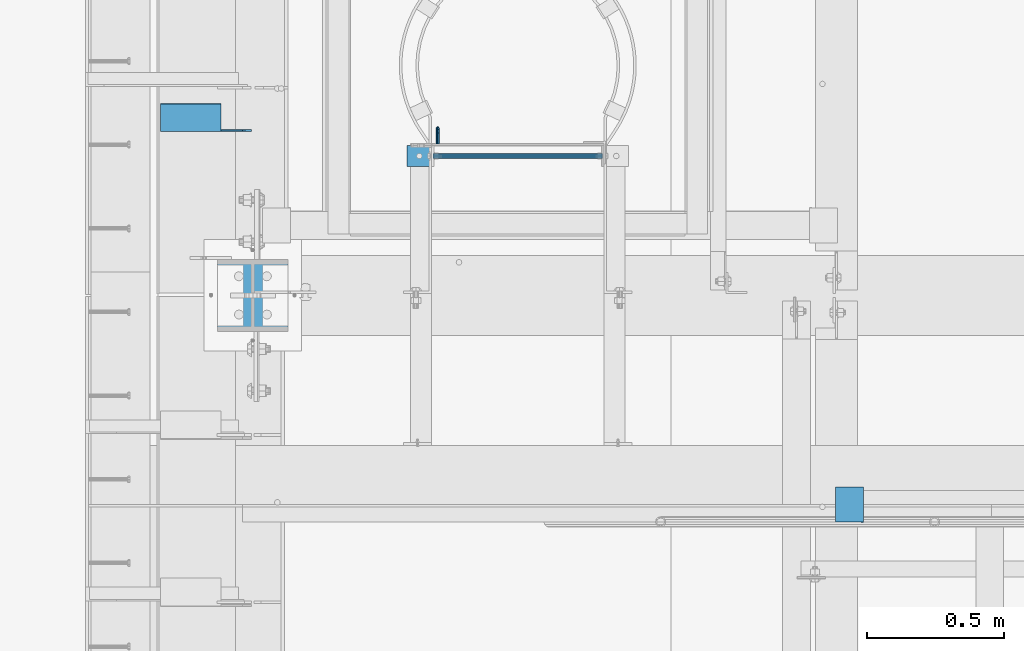
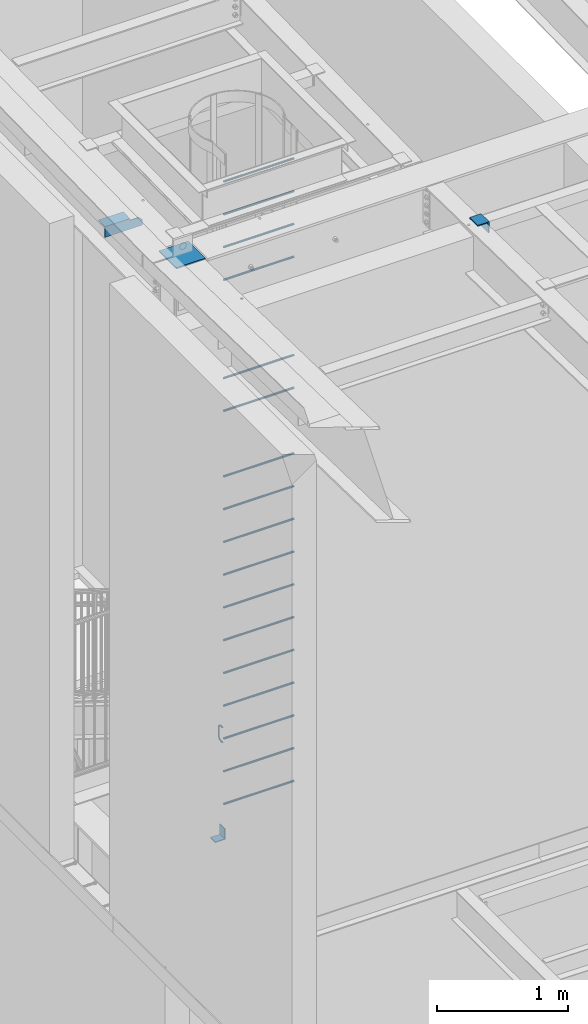
# One storey, part 1255 of 1763: 22 beams, 4 elements without a shape of their own.
"""IFC2X3 building model written with IfcOpenShell, lengths in millimetres."""

from ifc_helpers import new_model, si_unit, frame, origin_with_axes, place, context, subcontext, project, spatial, faceted_brep, material, type_object, element, aggregate, save


model = new_model("IFC2X3")

# Units and contexts
model_context = context("Model", 3, precision=1e-05, world=origin_with_axes())
body_context = subcontext(model_context, "Body", "Model", "MODEL_VIEW")
ifc_project = project(units=[si_unit("LENGTHUNIT", "METRE", prefix="MILLI"), si_unit("AREAUNIT", "SQUARE_METRE"), si_unit("VOLUMEUNIT", "CUBIC_METRE"), si_unit("MASSUNIT", "GRAM", prefix="KILO"), si_unit("TIMEUNIT", "SECOND"), si_unit("PLANEANGLEUNIT", "RADIAN"), si_unit("SOLIDANGLEUNIT", "STERADIAN"), si_unit("THERMODYNAMICTEMPERATUREUNIT", "DEGREE_CELSIUS"), si_unit("LUMINOUSINTENSITYUNIT", "LUMEN")], contexts=[model_context])

# Site, building, storey
site_placement = place(None, origin_with_axes())
site = spatial("IfcSite", under=ifc_project, at=site_placement, CompositionType="ELEMENT")
building_placement = place(site_placement, origin_with_axes())
building = spatial("IfcBuilding", under=site, at=building_placement, Name="Undefined", CompositionType="ELEMENT")
storey_placement = place(building_placement, origin_with_axes())
storey = spatial("IfcBuildingStorey", under=building, at=storey_placement, Name="Undefined", CompositionType="ELEMENT", Elevation=0.0)

# Assembly, beam
assembly_1_placement = place(storey_placement, origin_with_axes())
assembly_1 = element("IfcElementAssembly", 1, at=assembly_1_placement, inside=storey, Name="BEAM", AssemblyPlace="NOTDEFINED", PredefinedType="RIGID_FRAME")
ifc_material = material(Name="STEEL/A36")
beam_type_1 = type_object("IfcBeamType", Name="L4X4X1/4", PredefinedType="NOTDEFINED")
beam_1_placement = place(assembly_1_placement, frame((-87711.9872706466, 30671.4371696159, 11252.909207516), z_axis=(0.0, 0.0206852279954837, -0.999786037781472), x_axis=(1.0, 0.0, 0.0)))
beam_1 = element("IfcBeam", 2, at=beam_1_placement, type_object=beam_type_1, material=ifc_material, Name="BRACE", ObjectType="L4X4X1/4", context=body_context, shape_type="Brep", body=[
    faceted_brep([(220.662761923406, 44.4500000001208, -44.4499999999807), (220.662761962012, -50.800000000163, -44.4499999999553), (220.66276795695, -50.800000000163, -50.7999999999502), (220.662767915564, 50.8000000001339, -50.7999999999774), (220.662751535681, 50.8000000001339, -33.3786578752915), (220.662751538272, 44.4500000001208, -33.3786578752897), (299.243730570859, 44.4500000001135, -33.3375021376705), (299.243730570859, 50.8000000001339, -33.3375021376723), (2.11002770811319e-10, -50.8000000000357, -50.799999999952), (1.96450855582952e-10, -50.8000000000338, -44.4499999999534), (-2.18278728425503e-11, 44.4500000000007, -44.450000000048), (-1.81898940354586e-10, 44.4500000000371, 50.7999999999374), (-1.96450855582952e-10, 50.8000000000393, 50.7999999999374), (-3.63797880709171e-11, 50.8000000000011, -50.8000000000538), (330.993731689443, 44.4500000000007, 50.7999999999993), (330.993731689443, 50.7999999999993, 50.7999999999993), (330.993730570859, 44.4500000001281, -1.58750213774329), (330.993746948254, 50.8000000001412, -1.5875021377451)], [[[0, 1, 2, 3, 4, 5]], [[6, 5, 4, 7]], [[8, 9, 10, 11, 12, 13]], [[12, 11, 14, 15]], [[15, 14, 16, 17]], [[17, 16, 6, 7]], [[3, 13, 12, 15, 17, 7, 4]], [[8, 13, 3, 2]], [[9, 8, 2, 1]], [[10, 9, 1, 0]], [[16, 14, 11, 10, 0, 5, 6]]]),
])
aggregate(assembly_1, [beam_1])

assembly_2_placement = place(storey_placement, origin_with_axes())
assembly_2 = element("IfcElementAssembly", 3, at=assembly_2_placement, inside=storey, Name="ANGLE", AssemblyPlace="NOTDEFINED", PredefinedType="RIGID_FRAME")
beam_type_2 = type_object("IfcBeamType", Name="L4X4X3/8", PredefinedType="NOTDEFINED")
beam_2_placement = place(assembly_2_placement, frame((-85201.4694165555, 29196.4367267787, 11266.2929020441), z_axis=(0.0, -0.0209829029927569, -0.999779834654609), x_axis=(0.0, 0.999779834654609, -0.0209829029927566)))
beam_2 = element("IfcBeam", 4, at=beam_2_placement, type_object=beam_type_2, material=ifc_material, Name="ANGLE", ObjectType="L4X4X3/8", context=body_context, shape_type="Brep", body=[
    faceted_brep([(-3.63797880709171e-11, 50.8000000000011, -50.8000000000538), (-1.96450855582952e-10, 50.8000000000393, 50.7999999999374), (127.0, 50.7999999999993, 50.7999999999993), (127.0, 50.7999999999993, -50.7999999999993), (0.0, 41.2749999999996, 50.7999999999993), (127.0, 41.2749999999996, 50.7999999999993), (0.0, 41.2749999999996, -41.2750000000015), (127.0, 41.2749999999996, -41.2750000000015), (0.0, -50.7999999999993, -41.2750000000015), (127.0, -50.7999999999993, -41.2750000000015), (2.11002770811319e-10, -50.8000000000357, -50.799999999952), (127.0, -50.7999999999993, -50.7999999999993)], [[[0, 1, 2, 3]], [[1, 4, 5, 2]], [[4, 6, 7, 5]], [[6, 8, 9, 7]], [[8, 10, 11, 9]], [[10, 0, 3, 11]], [[5, 7, 9, 11, 3, 2]], [[10, 8, 6, 4, 1, 0]]]),
])
aggregate(assembly_2, [beam_2])

# Assembly, beams
assembly_3_placement = place(storey_placement, origin_with_axes())
assembly_3 = element("IfcElementAssembly", 5, at=assembly_3_placement, inside=storey, Name="LADDER", AssemblyPlace="NOTDEFINED", PredefinedType="RIGID_FRAME")
beam_type_3 = type_object("IfcBeamType", PredefinedType="NOTDEFINED")
beam_3_placement = place(assembly_3_placement, frame((-86813.4620801372, 30530.7999938243, 5337.17499999941), z_axis=(0.0, 1.0, 0.0), x_axis=(1.0, 0.0, 0.0)))
beam_3 = element("IfcBeam", 6, at=beam_3_placement, type_object=beam_type_3, material=ifc_material, Name="BENT_PLATE", context=body_context, shape_type="Brep", body=[
    faceted_brep([(0.0, -3.17500000000018, -38.0999999999985), (0.0, -3.17500000000018, 38.0999999999985), (0.0, 3.17500000000018, 38.0999999999985), (0.0, 3.17500000000018, -38.0999999999985), (88.9000015258789, 3.17499999999291, 38.0999999999985), (88.9000015258789, 3.17499999999291, -38.0999999999985), (82.5500015258731, -3.17500000000655, -38.0999999999985), (82.5500015258731, -3.17500000000655, 38.0999999999985), (88.9000015258789, -98.4249984741209, 38.0999999999985), (88.9000015258789, -98.4249984741209, -38.0999999999985), (82.5500015258731, -98.4249984741209, 38.0999999999985), (82.5500015258731, -98.4249984741209, -38.0999999999985)], [[[0, 1, 2, 3]], [[3, 2, 4, 5]], [[1, 0, 6, 7]], [[5, 4, 8, 9]], [[4, 2, 1, 7, 10, 8]], [[7, 6, 11, 10]], [[6, 0, 3, 5, 9, 11]], [[10, 11, 9, 8]]]),
])
beam_type_4 = type_object("IfcBeamType", PredefinedType="NOTDEFINED")
beam_4_placement = place(assembly_3_placement, frame((-86100.6747736991, 30530.8, 11430.0), z_axis=(0.0, -1.0, 0.0), x_axis=(-1.0, 0.0, 0.0)))
beam_4 = element("IfcBeam", 7, at=beam_4_placement, type_object=beam_type_4, material=ifc_material, Name="RUNG", context=body_context, shape_type="Brep", body=[
    faceted_brep([(0.0, -9.52500000000146, 0.0), (0.0, -6.73519209080041, -6.73519209079677), (619.125, -6.73519209080223, -6.73519209080041), (619.125, -9.52499999999964, 0.0), (0.0, 0.0, -9.52499999999418), (619.125, 0.0, -9.52500000000146), (0.0, 6.73519209080041, -6.73519209079677), (619.125, 6.73519209080223, -6.73519209080041), (0.0, 9.52500000000146, 0.0), (619.125, 9.52499999999964, 0.0), (0.0, 6.73519209080041, 6.73519209079677), (619.125, 6.73519209080223, 6.73519209080041), (0.0, 0.0, 9.52499999999418), (619.125, 0.0, 9.52500000000146), (0.0, -6.73519209080041, 6.73519209079677), (619.125, -6.73519209080223, 6.73519209080041)], [[[0, 1, 2, 3]], [[1, 4, 5, 2]], [[4, 6, 7, 5]], [[6, 8, 9, 7]], [[8, 10, 11, 9]], [[10, 12, 13, 11]], [[12, 14, 15, 13]], [[14, 0, 3, 15]], [[5, 7, 9, 11, 13, 15, 3, 2]], [[14, 12, 10, 8, 6, 4, 1, 0]]]),
])
beam_5_placement = place(assembly_3_placement, frame((-86100.6747736991, 30530.8, 11125.2), z_axis=(0.0, -1.0, 0.0), x_axis=(-1.0, 0.0, 0.0)))
beam_5 = element("IfcBeam", 8, at=beam_5_placement, type_object=beam_type_4, material=ifc_material, Name="RUNG", context=body_context, shape_type="Brep", body=[
    faceted_brep([(0.0, -9.52500000000146, 0.0), (0.0, -6.73519209080041, -6.73519209079677), (619.125, -6.73519209080223, -6.73519209080041), (619.125, -9.52499999999964, 0.0), (0.0, 0.0, -9.52499999999418), (619.125, 0.0, -9.52500000000146), (0.0, 6.73519209080041, -6.73519209079677), (619.125, 6.73519209080223, -6.73519209080041), (0.0, 9.52500000000146, 0.0), (619.125, 9.52499999999964, 0.0), (0.0, 6.73519209080041, 6.73519209079677), (619.125, 6.73519209080223, 6.73519209080041), (0.0, 0.0, 9.52499999999418), (619.125, 0.0, 9.52500000000146), (0.0, -6.73519209080041, 6.73519209079677), (619.125, -6.73519209080223, 6.73519209080041)], [[[0, 1, 2, 3]], [[1, 4, 5, 2]], [[4, 6, 7, 5]], [[6, 8, 9, 7]], [[8, 10, 11, 9]], [[10, 12, 13, 11]], [[12, 14, 15, 13]], [[14, 0, 3, 15]], [[5, 7, 9, 11, 13, 15, 3, 2]], [[14, 12, 10, 8, 6, 4, 1, 0]]]),
])
beam_6_placement = place(assembly_3_placement, frame((-86100.6747736991, 30530.8, 10820.4), z_axis=(0.0, -1.0, 0.0), x_axis=(-1.0, 0.0, 0.0)))
beam_6 = element("IfcBeam", 9, at=beam_6_placement, type_object=beam_type_4, material=ifc_material, Name="RUNG", context=body_context, shape_type="Brep", body=[
    faceted_brep([(0.0, -9.52500000000146, 0.0), (0.0, -6.73519209080041, -6.73519209079677), (619.125, -6.73519209080223, -6.73519209080041), (619.125, -9.52499999999964, 0.0), (0.0, 0.0, -9.52499999999418), (619.125, 0.0, -9.52500000000146), (0.0, 6.73519209080041, -6.73519209079677), (619.125, 6.73519209080223, -6.73519209080041), (0.0, 9.52500000000146, 0.0), (619.125, 9.52499999999964, 0.0), (0.0, 6.73519209080041, 6.73519209079677), (619.125, 6.73519209080223, 6.73519209080041), (0.0, 0.0, 9.52499999999418), (619.125, 0.0, 9.52500000000146), (0.0, -6.73519209080041, 6.73519209079677), (619.125, -6.73519209080223, 6.73519209080041)], [[[0, 1, 2, 3]], [[1, 4, 5, 2]], [[4, 6, 7, 5]], [[6, 8, 9, 7]], [[8, 10, 11, 9]], [[10, 12, 13, 11]], [[12, 14, 15, 13]], [[14, 0, 3, 15]], [[5, 7, 9, 11, 13, 15, 3, 2]], [[14, 12, 10, 8, 6, 4, 1, 0]]]),
])
beam_7_placement = place(assembly_3_placement, frame((-86100.6747736991, 30530.8, 10515.6), z_axis=(0.0, -1.0, 0.0), x_axis=(-1.0, 0.0, 0.0)))
beam_7 = element("IfcBeam", 10, at=beam_7_placement, type_object=beam_type_4, material=ifc_material, Name="RUNG", context=body_context, shape_type="Brep", body=[
    faceted_brep([(0.0, -9.52500000000146, 0.0), (0.0, -6.73519209080041, -6.73519209079677), (619.125, -6.73519209080223, -6.73519209080041), (619.125, -9.52499999999964, 0.0), (0.0, 0.0, -9.52499999999418), (619.125, 0.0, -9.52500000000146), (0.0, 6.73519209080041, -6.73519209079677), (619.125, 6.73519209080223, -6.73519209080041), (0.0, 9.52500000000146, 0.0), (619.125, 9.52499999999964, 0.0), (0.0, 6.73519209080041, 6.73519209079677), (619.125, 6.73519209080223, 6.73519209080041), (0.0, 0.0, 9.52499999999418), (619.125, 0.0, 9.52500000000146), (0.0, -6.73519209080041, 6.73519209079677), (619.125, -6.73519209080223, 6.73519209080041)], [[[0, 1, 2, 3]], [[1, 4, 5, 2]], [[4, 6, 7, 5]], [[6, 8, 9, 7]], [[8, 10, 11, 9]], [[10, 12, 13, 11]], [[12, 14, 15, 13]], [[14, 0, 3, 15]], [[5, 7, 9, 11, 13, 15, 3, 2]], [[14, 12, 10, 8, 6, 4, 1, 0]]]),
])
beam_8_placement = place(assembly_3_placement, frame((-86100.6747736991, 30530.8, 9296.4), z_axis=(0.0, -1.0, 0.0), x_axis=(-1.0, 0.0, 0.0)))
beam_8 = element("IfcBeam", 11, at=beam_8_placement, type_object=beam_type_4, material=ifc_material, Name="RUNG", context=body_context, shape_type="Brep", body=[
    faceted_brep([(0.0, -9.52500000000146, 0.0), (0.0, -6.73519209080041, -6.73519209079677), (619.125, -6.73519209080223, -6.73519209080041), (619.125, -9.52499999999964, 0.0), (0.0, 0.0, -9.52499999999418), (619.125, 0.0, -9.52500000000146), (0.0, 6.73519209080041, -6.73519209079677), (619.125, 6.73519209080223, -6.73519209080041), (0.0, 9.52500000000146, 0.0), (619.125, 9.52499999999964, 0.0), (0.0, 6.73519209080041, 6.73519209079677), (619.125, 6.73519209080223, 6.73519209080041), (0.0, 0.0, 9.52499999999418), (619.125, 0.0, 9.52500000000146), (0.0, -6.73519209080041, 6.73519209079677), (619.125, -6.73519209080223, 6.73519209080041)], [[[0, 1, 2, 3]], [[1, 4, 5, 2]], [[4, 6, 7, 5]], [[6, 8, 9, 7]], [[8, 10, 11, 9]], [[10, 12, 13, 11]], [[12, 14, 15, 13]], [[14, 0, 3, 15]], [[5, 7, 9, 11, 13, 15, 3, 2]], [[14, 12, 10, 8, 6, 4, 1, 0]]]),
])
beam_9_placement = place(assembly_3_placement, frame((-86100.6747736991, 30530.8, 9601.2), z_axis=(0.0, -1.0, 0.0), x_axis=(-1.0, 0.0, 0.0)))
beam_9 = element("IfcBeam", 12, at=beam_9_placement, type_object=beam_type_4, material=ifc_material, Name="RUNG", context=body_context, shape_type="Brep", body=[
    faceted_brep([(0.0, -9.52500000000146, 0.0), (0.0, -6.73519209080041, -6.73519209079677), (619.125, -6.73519209080223, -6.73519209080041), (619.125, -9.52499999999964, 0.0), (0.0, 0.0, -9.52499999999418), (619.125, 0.0, -9.52500000000146), (0.0, 6.73519209080041, -6.73519209079677), (619.125, 6.73519209080223, -6.73519209080041), (0.0, 9.52500000000146, 0.0), (619.125, 9.52499999999964, 0.0), (0.0, 6.73519209080041, 6.73519209079677), (619.125, 6.73519209080223, 6.73519209080041), (0.0, 0.0, 9.52499999999418), (619.125, 0.0, 9.52500000000146), (0.0, -6.73519209080041, 6.73519209079677), (619.125, -6.73519209080223, 6.73519209080041)], [[[0, 1, 2, 3]], [[1, 4, 5, 2]], [[4, 6, 7, 5]], [[6, 8, 9, 7]], [[8, 10, 11, 9]], [[10, 12, 13, 11]], [[12, 14, 15, 13]], [[14, 0, 3, 15]], [[5, 7, 9, 11, 13, 15, 3, 2]], [[14, 12, 10, 8, 6, 4, 1, 0]]]),
])
beam_10_placement = place(assembly_3_placement, frame((-86100.6747736991, 30530.8, 8686.8), z_axis=(0.0, -1.0, 0.0), x_axis=(-1.0, 0.0, 0.0)))
beam_10 = element("IfcBeam", 13, at=beam_10_placement, type_object=beam_type_4, material=ifc_material, Name="RUNG", context=body_context, shape_type="Brep", body=[
    faceted_brep([(0.0, -9.52500000000146, 0.0), (0.0, -6.73519209080041, -6.73519209079677), (619.125, -6.73519209080223, -6.73519209080041), (619.125, -9.52499999999964, 0.0), (0.0, 0.0, -9.52499999999418), (619.125, 0.0, -9.52500000000146), (0.0, 6.73519209080041, -6.73519209079677), (619.125, 6.73519209080223, -6.73519209080041), (0.0, 9.52500000000146, 0.0), (619.125, 9.52499999999964, 0.0), (0.0, 6.73519209080041, 6.73519209079677), (619.125, 6.73519209080223, 6.73519209080041), (0.0, 0.0, 9.52499999999418), (619.125, 0.0, 9.52500000000146), (0.0, -6.73519209080041, 6.73519209079677), (619.125, -6.73519209080223, 6.73519209080041)], [[[0, 1, 2, 3]], [[1, 4, 5, 2]], [[4, 6, 7, 5]], [[6, 8, 9, 7]], [[8, 10, 11, 9]], [[10, 12, 13, 11]], [[12, 14, 15, 13]], [[14, 0, 3, 15]], [[5, 7, 9, 11, 13, 15, 3, 2]], [[14, 12, 10, 8, 6, 4, 1, 0]]]),
])
beam_11_placement = place(assembly_3_placement, frame((-86100.6747736991, 30530.8, 8382.0), z_axis=(0.0, -1.0, 0.0), x_axis=(-1.0, 0.0, 0.0)))
beam_11 = element("IfcBeam", 14, at=beam_11_placement, type_object=beam_type_4, material=ifc_material, Name="RUNG", context=body_context, shape_type="Brep", body=[
    faceted_brep([(0.0, -9.52500000000146, 0.0), (0.0, -6.73519209080041, -6.73519209079677), (619.125, -6.73519209080223, -6.73519209080041), (619.125, -9.52499999999964, 0.0), (0.0, 0.0, -9.52499999999418), (619.125, 0.0, -9.52500000000146), (0.0, 6.73519209080041, -6.73519209079677), (619.125, 6.73519209080223, -6.73519209080041), (0.0, 9.52500000000146, 0.0), (619.125, 9.52499999999964, 0.0), (0.0, 6.73519209080041, 6.73519209079677), (619.125, 6.73519209080223, 6.73519209080041), (0.0, 0.0, 9.52499999999418), (619.125, 0.0, 9.52500000000146), (0.0, -6.73519209080041, 6.73519209079677), (619.125, -6.73519209080223, 6.73519209080041)], [[[0, 1, 2, 3]], [[1, 4, 5, 2]], [[4, 6, 7, 5]], [[6, 8, 9, 7]], [[8, 10, 11, 9]], [[10, 12, 13, 11]], [[12, 14, 15, 13]], [[14, 0, 3, 15]], [[5, 7, 9, 11, 13, 15, 3, 2]], [[14, 12, 10, 8, 6, 4, 1, 0]]]),
])
beam_12_placement = place(assembly_3_placement, frame((-86100.6747736991, 30530.8, 5638.8), z_axis=(0.0, -1.0, 0.0), x_axis=(-1.0, 0.0, 0.0)))
beam_12 = element("IfcBeam", 15, at=beam_12_placement, type_object=beam_type_4, material=ifc_material, Name="RUNG", context=body_context, shape_type="Brep", body=[
    faceted_brep([(0.0, -9.52500000000146, 0.0), (0.0, -6.73519209080041, -6.73519209079677), (619.125, -6.73519209080223, -6.73519209080041), (619.125, -9.52499999999964, 0.0), (0.0, 0.0, -9.52499999999418), (619.125, 0.0, -9.52500000000146), (0.0, 6.73519209080041, -6.73519209079677), (619.125, 6.73519209080223, -6.73519209080041), (0.0, 9.52500000000146, 0.0), (619.125, 9.52499999999964, 0.0), (0.0, 6.73519209080041, 6.73519209079677), (619.125, 6.73519209080223, 6.73519209080041), (0.0, 0.0, 9.52499999999418), (619.125, 0.0, 9.52500000000146), (0.0, -6.73519209080041, 6.73519209079677), (619.125, -6.73519209080223, 6.73519209080041)], [[[0, 1, 2, 3]], [[1, 4, 5, 2]], [[4, 6, 7, 5]], [[6, 8, 9, 7]], [[8, 10, 11, 9]], [[10, 12, 13, 11]], [[12, 14, 15, 13]], [[14, 0, 3, 15]], [[5, 7, 9, 11, 13, 15, 3, 2]], [[14, 12, 10, 8, 6, 4, 1, 0]]]),
])
beam_13_placement = place(assembly_3_placement, frame((-86100.6747736991, 30530.8, 5943.6), z_axis=(0.0, -1.0, 0.0), x_axis=(-1.0, 0.0, 0.0)))
beam_13 = element("IfcBeam", 16, at=beam_13_placement, type_object=beam_type_4, material=ifc_material, Name="RUNG", context=body_context, shape_type="Brep", body=[
    faceted_brep([(0.0, -9.52500000000146, 0.0), (0.0, -6.73519209080041, -6.73519209079677), (619.125, -6.73519209080223, -6.73519209080041), (619.125, -9.52499999999964, 0.0), (0.0, 0.0, -9.52499999999418), (619.125, 0.0, -9.52500000000146), (0.0, 6.73519209080041, -6.73519209079677), (619.125, 6.73519209080223, -6.73519209080041), (0.0, 9.52500000000146, 0.0), (619.125, 9.52499999999964, 0.0), (0.0, 6.73519209080041, 6.73519209079677), (619.125, 6.73519209080223, 6.73519209080041), (0.0, 0.0, 9.52499999999418), (619.125, 0.0, 9.52500000000146), (0.0, -6.73519209080041, 6.73519209079677), (619.125, -6.73519209080223, 6.73519209080041)], [[[0, 1, 2, 3]], [[1, 4, 5, 2]], [[4, 6, 7, 5]], [[6, 8, 9, 7]], [[8, 10, 11, 9]], [[10, 12, 13, 11]], [[12, 14, 15, 13]], [[14, 0, 3, 15]], [[5, 7, 9, 11, 13, 15, 3, 2]], [[14, 12, 10, 8, 6, 4, 1, 0]]]),
])
beam_14_placement = place(assembly_3_placement, frame((-86100.6747736991, 30530.8, 6248.4), z_axis=(0.0, -1.0, 0.0), x_axis=(-1.0, 0.0, 0.0)))
beam_14 = element("IfcBeam", 17, at=beam_14_placement, type_object=beam_type_4, material=ifc_material, Name="RUNG", context=body_context, shape_type="Brep", body=[
    faceted_brep([(0.0, -9.52500000000146, 0.0), (0.0, -6.73519209080041, -6.73519209079677), (619.125, -6.73519209080223, -6.73519209080041), (619.125, -9.52499999999964, 0.0), (0.0, 0.0, -9.52499999999418), (619.125, 0.0, -9.52500000000146), (0.0, 6.73519209080041, -6.73519209079677), (619.125, 6.73519209080223, -6.73519209080041), (0.0, 9.52500000000146, 0.0), (619.125, 9.52499999999964, 0.0), (0.0, 6.73519209080041, 6.73519209079677), (619.125, 6.73519209080223, 6.73519209080041), (0.0, 0.0, 9.52499999999418), (619.125, 0.0, 9.52500000000146), (0.0, -6.73519209080041, 6.73519209079677), (619.125, -6.73519209080223, 6.73519209080041)], [[[0, 1, 2, 3]], [[1, 4, 5, 2]], [[4, 6, 7, 5]], [[6, 8, 9, 7]], [[8, 10, 11, 9]], [[10, 12, 13, 11]], [[12, 14, 15, 13]], [[14, 0, 3, 15]], [[5, 7, 9, 11, 13, 15, 3, 2]], [[14, 12, 10, 8, 6, 4, 1, 0]]]),
])
beam_15_placement = place(assembly_3_placement, frame((-86100.6747736991, 30530.8, 6553.2), z_axis=(0.0, -1.0, 0.0), x_axis=(-1.0, 0.0, 0.0)))
beam_15 = element("IfcBeam", 18, at=beam_15_placement, type_object=beam_type_4, material=ifc_material, Name="RUNG", context=body_context, shape_type="Brep", body=[
    faceted_brep([(0.0, -9.52500000000146, 0.0), (0.0, -6.73519209080041, -6.73519209079677), (619.125, -6.73519209080223, -6.73519209080041), (619.125, -9.52499999999964, 0.0), (0.0, 0.0, -9.52499999999418), (619.125, 0.0, -9.52500000000146), (0.0, 6.73519209080041, -6.73519209079677), (619.125, 6.73519209080223, -6.73519209080041), (0.0, 9.52500000000146, 0.0), (619.125, 9.52499999999964, 0.0), (0.0, 6.73519209080041, 6.73519209079677), (619.125, 6.73519209080223, 6.73519209080041), (0.0, 0.0, 9.52499999999418), (619.125, 0.0, 9.52500000000146), (0.0, -6.73519209080041, 6.73519209079677), (619.125, -6.73519209080223, 6.73519209080041)], [[[0, 1, 2, 3]], [[1, 4, 5, 2]], [[4, 6, 7, 5]], [[6, 8, 9, 7]], [[8, 10, 11, 9]], [[10, 12, 13, 11]], [[12, 14, 15, 13]], [[14, 0, 3, 15]], [[5, 7, 9, 11, 13, 15, 3, 2]], [[14, 12, 10, 8, 6, 4, 1, 0]]]),
])
beam_16_placement = place(assembly_3_placement, frame((-86100.6747736991, 30530.8, 6858.0), z_axis=(0.0, -1.0, 0.0), x_axis=(-1.0, 0.0, 0.0)))
beam_16 = element("IfcBeam", 19, at=beam_16_placement, type_object=beam_type_4, material=ifc_material, Name="RUNG", context=body_context, shape_type="Brep", body=[
    faceted_brep([(0.0, -9.52500000000146, 0.0), (0.0, -6.73519209080041, -6.73519209079677), (619.125, -6.73519209080223, -6.73519209080041), (619.125, -9.52499999999964, 0.0), (0.0, 0.0, -9.52499999999418), (619.125, 0.0, -9.52500000000146), (0.0, 6.73519209080041, -6.73519209079677), (619.125, 6.73519209080223, -6.73519209080041), (0.0, 9.52500000000146, 0.0), (619.125, 9.52499999999964, 0.0), (0.0, 6.73519209080041, 6.73519209079677), (619.125, 6.73519209080223, 6.73519209080041), (0.0, 0.0, 9.52499999999418), (619.125, 0.0, 9.52500000000146), (0.0, -6.73519209080041, 6.73519209079677), (619.125, -6.73519209080223, 6.73519209080041)], [[[0, 1, 2, 3]], [[1, 4, 5, 2]], [[4, 6, 7, 5]], [[6, 8, 9, 7]], [[8, 10, 11, 9]], [[10, 12, 13, 11]], [[12, 14, 15, 13]], [[14, 0, 3, 15]], [[5, 7, 9, 11, 13, 15, 3, 2]], [[14, 12, 10, 8, 6, 4, 1, 0]]]),
])
beam_17_placement = place(assembly_3_placement, frame((-86100.6747736991, 30530.8, 7162.8), z_axis=(0.0, -1.0, 0.0), x_axis=(-1.0, 0.0, 0.0)))
beam_17 = element("IfcBeam", 20, at=beam_17_placement, type_object=beam_type_4, material=ifc_material, Name="RUNG", context=body_context, shape_type="Brep", body=[
    faceted_brep([(0.0, -9.52500000000146, 0.0), (0.0, -6.73519209080041, -6.73519209079677), (619.125, -6.73519209080223, -6.73519209080041), (619.125, -9.52499999999964, 0.0), (0.0, 0.0, -9.52499999999418), (619.125, 0.0, -9.52500000000146), (0.0, 6.73519209080041, -6.73519209079677), (619.125, 6.73519209080223, -6.73519209080041), (0.0, 9.52500000000146, 0.0), (619.125, 9.52499999999964, 0.0), (0.0, 6.73519209080041, 6.73519209079677), (619.125, 6.73519209080223, 6.73519209080041), (0.0, 0.0, 9.52499999999418), (619.125, 0.0, 9.52500000000146), (0.0, -6.73519209080041, 6.73519209079677), (619.125, -6.73519209080223, 6.73519209080041)], [[[0, 1, 2, 3]], [[1, 4, 5, 2]], [[4, 6, 7, 5]], [[6, 8, 9, 7]], [[8, 10, 11, 9]], [[10, 12, 13, 11]], [[12, 14, 15, 13]], [[14, 0, 3, 15]], [[5, 7, 9, 11, 13, 15, 3, 2]], [[14, 12, 10, 8, 6, 4, 1, 0]]]),
])
beam_18_placement = place(assembly_3_placement, frame((-86100.6747736991, 30530.8, 7467.6), z_axis=(0.0, -1.0, 0.0), x_axis=(-1.0, 0.0, 0.0)))
beam_18 = element("IfcBeam", 21, at=beam_18_placement, type_object=beam_type_4, material=ifc_material, Name="RUNG", context=body_context, shape_type="Brep", body=[
    faceted_brep([(0.0, -9.52500000000146, 0.0), (0.0, -6.73519209080041, -6.73519209079677), (619.125, -6.73519209080223, -6.73519209080041), (619.125, -9.52499999999964, 0.0), (0.0, 0.0, -9.52499999999418), (619.125, 0.0, -9.52500000000146), (0.0, 6.73519209080041, -6.73519209079677), (619.125, 6.73519209080223, -6.73519209080041), (0.0, 9.52500000000146, 0.0), (619.125, 9.52499999999964, 0.0), (0.0, 6.73519209080041, 6.73519209079677), (619.125, 6.73519209080223, 6.73519209080041), (0.0, 0.0, 9.52499999999418), (619.125, 0.0, 9.52500000000146), (0.0, -6.73519209080041, 6.73519209079677), (619.125, -6.73519209080223, 6.73519209080041)], [[[0, 1, 2, 3]], [[1, 4, 5, 2]], [[4, 6, 7, 5]], [[6, 8, 9, 7]], [[8, 10, 11, 9]], [[10, 12, 13, 11]], [[12, 14, 15, 13]], [[14, 0, 3, 15]], [[5, 7, 9, 11, 13, 15, 3, 2]], [[14, 12, 10, 8, 6, 4, 1, 0]]]),
])
beam_19_placement = place(assembly_3_placement, frame((-86100.6747736991, 30530.8, 7772.4), z_axis=(0.0, -1.0, 0.0), x_axis=(-1.0, 0.0, 0.0)))
beam_19 = element("IfcBeam", 22, at=beam_19_placement, type_object=beam_type_4, material=ifc_material, Name="RUNG", context=body_context, shape_type="Brep", body=[
    faceted_brep([(0.0, -9.52500000000146, 0.0), (0.0, -6.73519209080041, -6.73519209079677), (619.125, -6.73519209080223, -6.73519209080041), (619.125, -9.52499999999964, 0.0), (0.0, 0.0, -9.52499999999418), (619.125, 0.0, -9.52500000000146), (0.0, 6.73519209080041, -6.73519209079677), (619.125, 6.73519209080223, -6.73519209080041), (0.0, 9.52500000000146, 0.0), (619.125, 9.52499999999964, 0.0), (0.0, 6.73519209080041, 6.73519209079677), (619.125, 6.73519209080223, 6.73519209080041), (0.0, 0.0, 9.52499999999418), (619.125, 0.0, 9.52500000000146), (0.0, -6.73519209080041, 6.73519209079677), (619.125, -6.73519209080223, 6.73519209080041)], [[[0, 1, 2, 3]], [[1, 4, 5, 2]], [[4, 6, 7, 5]], [[6, 8, 9, 7]], [[8, 10, 11, 9]], [[10, 12, 13, 11]], [[12, 14, 15, 13]], [[14, 0, 3, 15]], [[5, 7, 9, 11, 13, 15, 3, 2]], [[14, 12, 10, 8, 6, 4, 1, 0]]]),
])
beam_20_placement = place(assembly_3_placement, frame((-86100.6747736991, 30530.8, 8077.2), z_axis=(0.0, -1.0, 0.0), x_axis=(-1.0, 0.0, 0.0)))
beam_20 = element("IfcBeam", 23, at=beam_20_placement, type_object=beam_type_4, material=ifc_material, Name="RUNG", context=body_context, shape_type="Brep", body=[
    faceted_brep([(0.0, -9.52500000000146, 0.0), (0.0, -6.73519209080041, -6.73519209079677), (619.125, -6.73519209080223, -6.73519209080041), (619.125, -9.52499999999964, 0.0), (0.0, 0.0, -9.52499999999418), (619.125, 0.0, -9.52500000000146), (0.0, 6.73519209080041, -6.73519209079677), (619.125, 6.73519209080223, -6.73519209080041), (0.0, 9.52500000000146, 0.0), (619.125, 9.52499999999964, 0.0), (0.0, 6.73519209080041, 6.73519209079677), (619.125, 6.73519209080223, 6.73519209080041), (0.0, 0.0, 9.52499999999418), (619.125, 0.0, 9.52500000000146), (0.0, -6.73519209080041, 6.73519209079677), (619.125, -6.73519209080223, 6.73519209080041)], [[[0, 1, 2, 3]], [[1, 4, 5, 2]], [[4, 6, 7, 5]], [[6, 8, 9, 7]], [[8, 10, 11, 9]], [[10, 12, 13, 11]], [[12, 14, 15, 13]], [[14, 0, 3, 15]], [[5, 7, 9, 11, 13, 15, 3, 2]], [[14, 12, 10, 8, 6, 4, 1, 0]]]),
])
beam_type_5 = type_object("IfcBeamType", PredefinedType="NOTDEFINED")
beam_21_placement = place(assembly_3_placement, frame((-86702.3372736992, 30575.25, 6318.25), z_axis=(0.0, 0.0, -1.0), x_axis=(0.0, 1.0, 0.0)))
beam_21 = element("IfcBeam", 24, at=beam_21_placement, type_object=beam_type_5, material=ifc_material, Name="ROD", context=body_context, shape_type="Brep", body=[
    faceted_brep([(0.0, -6.34999999999491, 1.45519152283669e-11), (-1.13686837721616e-13, -4.49012806053361, -4.49012806058454), (25.3999996185339, -4.49012806054088, -4.49012806053452), (25.3999996185339, -6.35000000000582, 0.0), (0.0, 0.0, -6.34999990463257), (25.3999996185339, 0.0, -6.35000000000036), (0.0, 4.49012806054088, -4.49012806053452), (25.3999996185339, 4.49012806054088, -4.49012806053452), (0.0, 6.34999999999491, -2.91038304567337e-11), (25.3999996185339, 6.35000000000582, 0.0), (0.0, 4.49012806054088, 4.49012806053452), (25.3999996185339, 4.49012806054088, 4.49012806053452), (0.0, 0.0, 6.34999990463257), (25.3999996185339, 0.0, 6.35000000000036), (0.0, -4.49012806053361, 4.49012806055543), (25.3999996185339, -4.49012806054088, 4.49012806053452), (39.9802382456619, 0.0, -3.44981021771673), (39.2684960681072, -4.49012806054088, -1.73151259975293), (37.5501984501425, -6.35000000000582, 2.41682481372936), (35.8319008321778, -4.49012806054088, 6.56516222721166), (35.1201586546231, 0.0, 8.28345984517637), (35.8319008321778, 4.49012806054088, 6.56516222721166), (37.5501984501425, 6.35000000000582, 2.41682481372936), (39.2684960681072, 4.49012806054088, -1.73151259975293), (51.0256396514669, 4.49012806054088, 6.12435958560036), (52.3407677120013, 0.0, 4.80923152506602), (47.8506396514676, 6.35000000000582, 9.29935958559963), (44.6756396514684, 4.49012806054088, 12.4743595855998), (43.360511590934, 0.0, 13.7894876461341), (44.6756396514684, -4.49012806054088, 12.4743595855998), (47.8506396514676, -6.35000000000582, 9.29935958559963), (51.0256396514669, -4.49012806054088, 6.12435958560036), (58.8815118368148, 4.49012806054088, 17.881503168951), (60.5998094547758, 0.0, 17.1697609913963), (54.7331744233306, 6.35000000000582, 19.5998007869157), (50.5848370098502, 4.49012806054088, 21.3180984048804), (48.8665393918855, 0.0, 22.0298405824351), (50.5848370098502, -4.49012806054088, 21.3180984048804), (54.7331744233306, -6.35000000000582, 19.5998007869157), (58.8815118368148, -4.49012806054088, 17.881503168951), (61.6401272975963, 4.49012806054088, 31.7499996185306), (63.4999992370613, 0.0, 31.7499996185306), (57.1499992370627, 6.35000000000582, 31.7499996185306), (52.6598711765291, 4.49012806054088, 31.7499996185306), (50.7999992370642, 0.0, 31.7499996185306), (52.6598711765291, -4.49012806054088, 31.7499996185306), (57.1499992370627, -6.35000000000582, 31.7499996185306), (61.6401272975963, -4.49012806054088, 31.7499996185306), (61.6401272975963, -4.49012806054088, 107.95000038147), (57.1499992370627, -6.35000000000582, 107.95000038147), (63.4999992370613, 0.0, 107.95000038147), (61.6401272975963, 4.49012806054088, 107.95000038147), (57.1499992370627, 6.35000000000582, 107.95000038147), (52.6598711765291, 4.49012806054088, 107.95000038147), (50.7999992370642, 0.0, 107.95000038147), (52.6598711765291, -4.49012806054088, 107.95000038147), (60.5998094547795, 0.0, 122.530239008599), (58.8815118368148, -4.49012806054088, 121.818496831045), (54.7331744233343, -6.35000000000582, 120.10019921308), (50.5848370098502, -4.49012806054088, 118.381901595117), (48.8665393918855, 0.0, 117.670159417562), (50.5848370098502, 4.49012806054088, 118.381901595117), (54.7331744233343, 6.35000000000582, 120.10019921308), (58.8815118368148, 4.49012806054088, 121.818496831045), (51.0256396514669, 4.49012806054088, 133.575640414401), (52.3407677120013, 0.0, 134.890768474937), (47.8506396514676, 6.35000000000582, 130.400640414402), (44.6756396514684, 4.49012806054088, 127.225640414402), (43.360511590934, 0.0, 125.910512353867), (44.6756396514684, -4.49012806054088, 127.225640414402), (47.8506396514676, -6.35000000000582, 130.400640414402), (51.0256396514669, -4.49012806054088, 133.575640414401), (39.2684960681072, 4.49012806054088, 141.431512599755), (39.9802382456619, 0.0, 143.149810217719), (37.5501984501425, 6.35000000000582, 137.283175186272), (35.8319008321778, 4.49012806054088, 133.13483777279), (35.1201586546231, 0.0, 131.416540154825), (35.8319008321778, -4.49012806054088, 133.13483777279), (37.5501984501425, -6.35000000000582, 137.283175186272), (39.2684960681072, -4.49012806054088, 141.431512599755), (25.3999996185339, 4.49012806054088, 144.190128060536), (25.3999996185339, 0.0, 146.050000000002), (25.3999996185339, 6.35000000000582, 139.700000000002), (25.3999996185339, 4.49012806054088, 135.209871939467), (25.3999996185339, 0.0, 133.350000000001), (25.3999996185339, -4.49012806054088, 135.209871939467), (25.3999996185339, -6.35000000000582, 139.700000000001), (25.3999996185339, -4.49012806054088, 144.190128060536), (0.0, -4.49012806054088, 144.190128060535), (0.0, -6.35000000000582, 139.700000000001), (0.0, 0.0, 146.050000000001), (0.0, 4.49012806054088, 144.190128060535), (0.0, 6.35000000000582, 139.700000000001), (0.0, 4.49012806054088, 135.209871939466), (0.0, 0.0, 133.35), (0.0, -4.49012806054088, 135.209871939466)], [[[0, 1, 2, 3]], [[1, 4, 5, 2]], [[4, 6, 7, 5]], [[6, 8, 9, 7]], [[8, 10, 11, 9]], [[10, 12, 13, 11]], [[12, 14, 15, 13]], [[14, 0, 3, 15]], [[14, 12, 10, 8, 6, 4, 1, 0]], [[2, 5, 16, 17]], [[3, 2, 17, 18]], [[15, 3, 18, 19]], [[13, 15, 19, 20]], [[11, 13, 20, 21]], [[9, 11, 21, 22]], [[7, 9, 22, 23]], [[5, 7, 23, 16]], [[23, 24, 25, 16]], [[22, 26, 24, 23]], [[21, 27, 26, 22]], [[20, 28, 27, 21]], [[19, 29, 28, 20]], [[18, 30, 29, 19]], [[17, 31, 30, 18]], [[16, 25, 31, 17]], [[24, 32, 33, 25]], [[26, 34, 32, 24]], [[27, 35, 34, 26]], [[28, 36, 35, 27]], [[29, 37, 36, 28]], [[30, 38, 37, 29]], [[31, 39, 38, 30]], [[25, 33, 39, 31]], [[32, 40, 41, 33]], [[34, 42, 40, 32]], [[35, 43, 42, 34]], [[36, 44, 43, 35]], [[37, 45, 44, 36]], [[38, 46, 45, 37]], [[39, 47, 46, 38]], [[33, 41, 47, 39]], [[46, 47, 48, 49]], [[47, 41, 50, 48]], [[41, 40, 51, 50]], [[40, 42, 52, 51]], [[42, 43, 53, 52]], [[43, 44, 54, 53]], [[44, 45, 55, 54]], [[45, 46, 49, 55]], [[48, 50, 56, 57]], [[49, 48, 57, 58]], [[55, 49, 58, 59]], [[54, 55, 59, 60]], [[53, 54, 60, 61]], [[52, 53, 61, 62]], [[51, 52, 62, 63]], [[50, 51, 63, 56]], [[63, 64, 65, 56]], [[62, 66, 64, 63]], [[61, 67, 66, 62]], [[60, 68, 67, 61]], [[59, 69, 68, 60]], [[58, 70, 69, 59]], [[57, 71, 70, 58]], [[56, 65, 71, 57]], [[64, 72, 73, 65]], [[66, 74, 72, 64]], [[67, 75, 74, 66]], [[68, 76, 75, 67]], [[69, 77, 76, 68]], [[70, 78, 77, 69]], [[71, 79, 78, 70]], [[65, 73, 79, 71]], [[72, 80, 81, 73]], [[74, 82, 80, 72]], [[75, 83, 82, 74]], [[76, 84, 83, 75]], [[77, 85, 84, 76]], [[78, 86, 85, 77]], [[79, 87, 86, 78]], [[73, 81, 87, 79]], [[86, 87, 88, 89]], [[87, 81, 90, 88]], [[81, 80, 91, 90]], [[80, 82, 92, 91]], [[82, 83, 93, 92]], [[83, 84, 94, 93]], [[84, 85, 95, 94]], [[85, 86, 89, 95]], [[90, 91, 92, 93, 94, 95, 89, 88]]]),
])
aggregate(assembly_3, [beam_21, beam_3, beam_4, beam_5, beam_6, beam_7, beam_8, beam_9, beam_10, beam_11, beam_12, beam_13, beam_14, beam_15, beam_16, beam_17, beam_18, beam_19, beam_20])

# Assembly, beam
assembly_4_placement = place(storey_placement, origin_with_axes())
assembly_4 = element("IfcElementAssembly", 25, at=assembly_4_placement, inside=storey, Name="COLUMN", AssemblyPlace="NOTDEFINED", PredefinedType="RIGID_FRAME")
beam_type_6 = type_object("IfcBeamType", PredefinedType="NOTDEFINED")
beam_22_placement = place(assembly_4_placement, frame((-87375.4372736983, 29891.0375, 11283.95), z_axis=(1.0, 0.0, 0.0), x_axis=(0.0, 1.0, 0.0)))
beam_22 = element("IfcBeam", 26, at=beam_22_placement, type_object=beam_type_6, material=ifc_material, Name="PLATE", context=body_context, shape_type="Brep", body=[
    faceted_brep([(0.0, 6.35000000000036, -128.587500000001), (0.0, 6.35000000000036, 128.587500000001), (263.525000000001, 6.35000000000036, 128.587500000001), (263.525000000001, 6.35000000000036, -128.587500000001), (0.0, -6.35000000000036, 128.587500000001), (263.525000000001, -6.35000000000036, 128.587500000001), (0.0, -6.35000000000036, -128.587500000001), (263.525000000001, -6.35000000000036, -128.587500000001)], [[[0, 1, 2, 3]], [[1, 4, 5, 2]], [[4, 6, 7, 5]], [[6, 0, 3, 7]], [[5, 7, 3, 2]], [[6, 4, 1, 0]]]),
])
aggregate(assembly_4, [beam_22])

save(model, "model.ifc")
